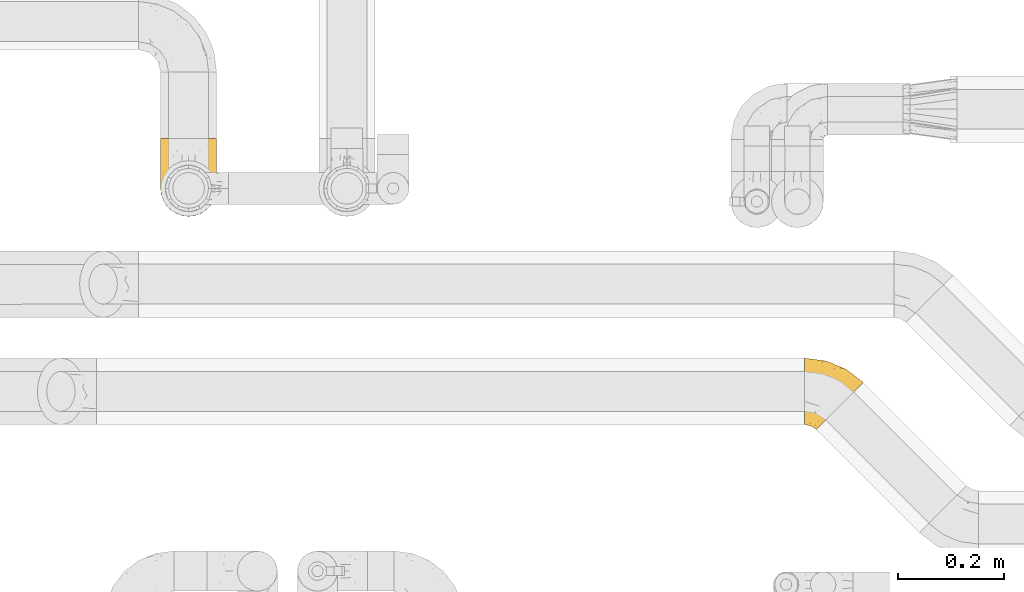
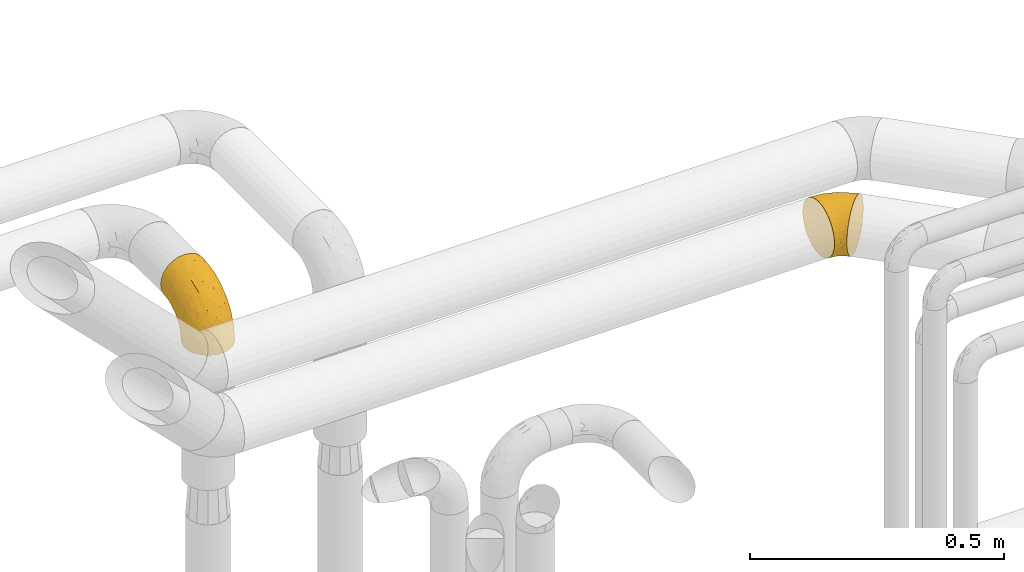
# One storey, part 407 of 827: 2 coverings.
"""IFC2X3 building model written with IfcOpenShell, lengths in millimetres."""

from ifc_helpers import new_model, entity, si_unit, converted_unit, derived_unit, direction, frame, origin, place, context, subcontext, project, spatial, faceted_brep, element, save


model = new_model("IFC2X3")

# Units and contexts
model_context = context("Model", 3, precision=0.01, world=origin(), true_north=direction((6.12303176911189e-17, 1.0)))
body_context = subcontext(model_context, "Body", "Model", "MODEL_VIEW")
ifc_project = project(units=[si_unit("LENGTHUNIT", "METRE", prefix="MILLI"), si_unit("AREAUNIT", "SQUARE_METRE"), si_unit("VOLUMEUNIT", "CUBIC_METRE"), converted_unit("PLANEANGLEUNIT", "DEGREE", entity("IfcRatioMeasure", 0.0174532925199433), si_unit("PLANEANGLEUNIT", "RADIAN"), dimensions=[0, 0, 0, 0, 0, 0, 0]), si_unit("MASSUNIT", "GRAM", prefix="KILO"), derived_unit("MASSDENSITYUNIT", [(si_unit("MASSUNIT", "GRAM", prefix="KILO"), 1), (si_unit("LENGTHUNIT", "METRE"), -3)]), derived_unit("MOMENTOFINERTIAUNIT", [(si_unit("LENGTHUNIT", "METRE"), 4)]), si_unit("TIMEUNIT", "SECOND"), si_unit("FREQUENCYUNIT", "HERTZ"), si_unit("THERMODYNAMICTEMPERATUREUNIT", "DEGREE_CELSIUS"), derived_unit("THERMALTRANSMITTANCEUNIT", [(si_unit("MASSUNIT", "GRAM", prefix="KILO"), 1), (si_unit("THERMODYNAMICTEMPERATUREUNIT", "KELVIN"), -1), (si_unit("TIMEUNIT", "SECOND"), -3)]), derived_unit("VOLUMETRICFLOWRATEUNIT", [(si_unit("LENGTHUNIT", "METRE"), 3), (si_unit("TIMEUNIT", "SECOND"), -1)]), derived_unit("MASSFLOWRATEUNIT", [(si_unit("MASSUNIT", "GRAM", prefix="KILO"), 1), (si_unit("TIMEUNIT", "SECOND"), -1)]), derived_unit("ROTATIONALFREQUENCYUNIT", [(si_unit("TIMEUNIT", "SECOND"), -1)]), si_unit("ELECTRICCURRENTUNIT", "AMPERE"), si_unit("ELECTRICVOLTAGEUNIT", "VOLT"), si_unit("POWERUNIT", "WATT"), si_unit("FORCEUNIT", "NEWTON", prefix="KILO"), si_unit("ILLUMINANCEUNIT", "LUX"), si_unit("LUMINOUSFLUXUNIT", "LUMEN"), si_unit("LUMINOUSINTENSITYUNIT", "CANDELA"), derived_unit("USERDEFINED", [(si_unit("MASSUNIT", "GRAM", prefix="KILO"), -1), (si_unit("LENGTHUNIT", "METRE"), -2), (si_unit("TIMEUNIT", "SECOND"), 3), (si_unit("LUMINOUSFLUXUNIT", "LUMEN"), 1)]), derived_unit("LINEARVELOCITYUNIT", [(si_unit("LENGTHUNIT", "METRE"), 1), (si_unit("TIMEUNIT", "SECOND"), -1)]), si_unit("PRESSUREUNIT", "PASCAL"), derived_unit("USERDEFINED", [(si_unit("LENGTHUNIT", "METRE"), -2), (si_unit("MASSUNIT", "GRAM", prefix="KILO"), 1), (si_unit("TIMEUNIT", "SECOND"), -2)]), derived_unit("LINEARFORCEUNIT", [(si_unit("MASSUNIT", "GRAM", prefix="KILO"), 1), (si_unit("LENGTHUNIT", "METRE"), 1), (si_unit("TIMEUNIT", "SECOND"), -2), (si_unit("LENGTHUNIT", "METRE"), -1)]), derived_unit("PLANARFORCEUNIT", [(si_unit("MASSUNIT", "GRAM", prefix="KILO"), 1), (si_unit("LENGTHUNIT", "METRE"), 1), (si_unit("TIMEUNIT", "SECOND"), -2), (si_unit("LENGTHUNIT", "METRE"), -2)])], contexts=[model_context])

# Site, building, storey
site_placement = place(None, origin())
site = spatial("IfcSite", under=ifc_project, at=site_placement, CompositionType="ELEMENT")
building_placement = place(site_placement, origin())
building = spatial("IfcBuilding", under=site, at=building_placement, CompositionType="ELEMENT")
storey_placement = place(building_placement, frame((0.0, 0.0, 28200.0)))
storey = spatial("IfcBuildingStorey", under=building, at=storey_placement, Name="08", CompositionType="ELEMENT", Elevation=28200.0)

# Coverings
covering_1_placement = place(storey_placement, frame((47672.87, 18532.7, 2935.35)))
element("IfcCovering", 1, at=covering_1_placement, inside=storey, Name=":ADSK_", ObjectType=":ADSK_", PredefinedType="INSULATION", context=body_context, shape_type="Brep", body=[
    faceted_brep([(1.6, 12.53, 50.61), (1.6, 10.95, 64.65), (1.6, 12.53, 78.67), (1.6, 17.2, 92.0), (1.6, 24.71, 103.95), (1.6, 34.69, 113.94), (1.6, 46.64, 121.45), (1.6, 59.97, 126.11), (1.6, 74.0, 127.7), (1.6, 88.03, 126.11), (1.6, 101.36, 121.45), (1.6, 113.31, 113.94), (1.6, 123.3, 103.96), (1.6, 130.81, 92.0), (1.6, 135.47, 78.68), (1.6, 137.05, 64.65), (1.6, 135.47, 50.62), (1.6, 130.81, 37.29), (1.6, 123.3, 25.34), (1.6, 113.32, 15.35), (1.6, 101.36, 7.84), (1.6, 88.04, 3.18), (1.6, 74.0, 1.6), (1.6, 59.97, 3.18), (1.6, 46.65, 7.84), (1.6, 34.69, 15.35), (1.6, 24.71, 25.33), (1.6, 17.2, 37.29), (24.19, 1.6, 64.65), (25.71, 3.11, 48.33), (30.16, 7.57, 33.12), (37.25, 14.65, 20.06), (46.48, 23.89, 10.04), (57.23, 34.64, 3.74), (68.77, 46.18, 1.6), (80.31, 57.72, 3.74), (91.06, 68.47, 10.04), (100.3, 77.7, 20.06), (107.38, 84.79, 33.12), (111.83, 89.24, 48.33), (113.35, 90.76, 64.65), (111.83, 89.24, 80.96), (107.38, 84.79, 96.17), (100.3, 77.7, 109.23), (91.06, 68.47, 119.25), (80.31, 57.72, 125.55), (68.77, 46.18, 127.7), (57.23, 34.64, 125.55), (46.48, 23.89, 119.25), (37.25, 14.65, 109.23), (30.16, 7.57, 96.17), (25.71, 3.11, 80.96), (32.7, 116.2, 108.1), (80.62, 115.88, 64.65), (93.11, 105.47, 80.19), (82.84, 100.01, 102.05), (42.5, 131.67, 64.65), (71.97, 118.02, 81.27), (45.26, 84.43, 124.73), (69.34, 78.79, 122.26), (36.12, 129.91, 84.6), (59.89, 101.26, 113.02), (49.1, 61.28, 127.7), (58.8, 53.83, 127.7), (28.22, 125.53, 97.32), (57.99, 117.49, 96.3), (28.36, 106.16, 117.12), (88.29, 104.46, 90.52), (14.06, 72.36, 127.7), (26.18, 70.77, 127.7), (37.64, 66.02, 127.7), (49.88, 94.73, 119.88), (12.25, 43.42, 120.26), (14.66, 57.99, 125.9), (44.99, 42.69, 125.09), (33.47, 31.37, 117.94), (14.23, 31.23, 112.32), (24.69, 45.08, 122.53), (18.1, 20.17, 102.2), (28.08, 17.46, 105.16), (23.85, 27.0, 111.58), (8.9, 21.15, 99.98), (19.06, 6.66, 74.42), (13.18, 13.45, 87.77), (10.63, 10.72, 75.98), (27.52, 58.08, 126.59), (35.9, 50.06, 125.61), (22.27, 10.21, 90.37), (13.82, 8.52, 64.65), (13.18, 13.45, 41.51), (14.23, 31.24, 16.97), (17.42, 8.21, 52.07), (33.46, 31.38, 11.35), (44.99, 42.69, 4.2), (21.94, 12.47, 35.35), (18.11, 20.17, 27.09), (58.8, 53.83, 1.6), (27.53, 58.09, 2.7), (26.18, 70.77, 1.6), (37.64, 66.02, 1.6), (12.25, 43.43, 9.03), (24.69, 45.08, 6.76), (37.86, 53.03, 2.86), (35.77, 41.85, 6.13), (28.08, 17.46, 24.13), (23.85, 27.0, 17.7), (14.66, 57.99, 3.39), (8.9, 21.16, 29.31), (14.06, 72.36, 1.6), (49.1, 61.28, 1.6), (45.26, 84.43, 4.56), (69.34, 78.79, 7.03), (32.7, 116.21, 21.19), (59.88, 101.26, 16.27), (28.36, 106.17, 12.17), (28.23, 125.53, 31.97), (57.99, 117.5, 33.0), (82.84, 100.01, 27.24), (93.11, 105.47, 49.11), (88.29, 104.46, 38.77), (36.12, 129.91, 44.69), (71.97, 118.03, 48.02), (49.88, 94.73, 9.41)], [[[0, 1, 2, 3, 4, 5, 6, 7, 8, 9, 10, 11, 12, 13, 14, 15, 16, 17, 18, 19, 20, 21, 22, 23, 24, 25, 26, 27]], [[28, 29, 30, 31, 32, 33, 34, 35, 36, 37, 38, 39, 40, 41, 42, 43, 44, 45, 46, 47, 48, 49, 50, 51]], [[52, 12, 11]], [[40, 53, 54]], [[42, 55, 43]], [[53, 56, 57]], [[10, 9, 58]], [[45, 59, 58]], [[56, 14, 60]], [[61, 44, 43]], [[45, 62, 63, 46]], [[62, 45, 58]], [[59, 45, 44]], [[64, 52, 65]], [[55, 61, 43]], [[61, 65, 52]], [[60, 57, 56]], [[60, 65, 57]], [[52, 11, 66]], [[64, 13, 12]], [[64, 60, 13]], [[14, 56, 15]], [[61, 55, 65]], [[67, 55, 42]], [[54, 67, 41]], [[61, 52, 66]], [[66, 11, 10]], [[9, 8, 68, 69]], [[58, 69, 70, 62]], [[58, 9, 69]], [[60, 64, 65]], [[52, 64, 12]], [[58, 59, 71]], [[54, 57, 67]], [[58, 66, 10]], [[60, 14, 13]], [[41, 67, 42]], [[65, 55, 67]], [[65, 67, 57]], [[40, 54, 41]], [[53, 57, 54]], [[44, 61, 59]], [[58, 71, 66]], [[59, 61, 71]], [[61, 66, 71]], [[72, 73, 6]], [[62, 74, 63]], [[48, 75, 49]], [[63, 74, 47]], [[75, 48, 74]], [[72, 76, 77]], [[78, 79, 80]], [[81, 4, 3]], [[82, 28, 51]], [[83, 84, 82]], [[73, 77, 85]], [[86, 62, 70]], [[83, 87, 78]], [[50, 87, 51]], [[86, 75, 74]], [[68, 73, 69]], [[6, 5, 72]], [[73, 7, 6]], [[74, 48, 47]], [[73, 68, 7]], [[80, 77, 76]], [[69, 85, 70]], [[81, 76, 4]], [[88, 84, 1]], [[84, 83, 2]], [[2, 83, 3]], [[4, 76, 5]], [[50, 49, 79]], [[83, 78, 81]], [[80, 76, 78]], [[73, 72, 77]], [[76, 72, 5]], [[85, 86, 70]], [[68, 8, 7]], [[73, 85, 69]], [[86, 85, 77]], [[75, 86, 77]], [[86, 74, 62]], [[47, 46, 63]], [[83, 81, 3]], [[76, 81, 78]], [[75, 79, 49]], [[87, 79, 78]], [[79, 75, 80]], [[77, 80, 75]], [[1, 84, 2]], [[82, 84, 88]], [[28, 82, 88]], [[82, 51, 87]], [[87, 50, 79]], [[82, 87, 83]], [[0, 27, 89]], [[26, 25, 90]], [[88, 91, 28]], [[32, 92, 93]], [[94, 89, 95]], [[94, 29, 91]], [[93, 96, 33]], [[97, 98, 99]], [[25, 24, 100]], [[101, 102, 103]], [[104, 95, 105]], [[93, 33, 32]], [[100, 90, 25]], [[102, 97, 99]], [[91, 0, 89]], [[97, 106, 98]], [[27, 107, 89]], [[93, 92, 103]], [[90, 95, 107]], [[31, 92, 32]], [[31, 30, 104]], [[107, 27, 26]], [[24, 23, 106]], [[101, 97, 102]], [[89, 94, 91]], [[31, 104, 92]], [[98, 106, 108]], [[106, 23, 108]], [[100, 106, 101]], [[101, 92, 105]], [[106, 100, 24]], [[0, 88, 1]], [[90, 100, 101]], [[23, 22, 108]], [[93, 102, 109]], [[106, 97, 101]], [[109, 102, 99]], [[102, 93, 103]], [[96, 93, 109]], [[96, 34, 33]], [[101, 103, 92]], [[90, 107, 26]], [[89, 107, 95]], [[94, 104, 30]], [[95, 90, 105]], [[101, 105, 90]], [[92, 104, 105]], [[104, 94, 95]], [[29, 94, 30]], [[28, 91, 29]], [[0, 91, 88]], [[35, 110, 111]], [[112, 113, 114]], [[35, 34, 96, 109]], [[112, 114, 19]], [[112, 115, 116]], [[117, 113, 116]], [[39, 118, 40]], [[116, 119, 117]], [[120, 121, 116]], [[113, 117, 37]], [[36, 113, 37]], [[38, 117, 119]], [[119, 116, 121]], [[21, 20, 110]], [[110, 109, 99, 98]], [[122, 111, 110]], [[21, 98, 108, 22]], [[37, 117, 38]], [[112, 19, 18]], [[39, 119, 118]], [[116, 113, 112]], [[110, 35, 109]], [[119, 39, 38]], [[114, 20, 19]], [[121, 120, 56]], [[115, 18, 17]], [[16, 15, 56]], [[16, 56, 120]], [[110, 20, 114]], [[115, 120, 116]], [[121, 56, 53]], [[16, 120, 17]], [[115, 112, 18]], [[21, 110, 98]], [[120, 115, 17]], [[35, 111, 36]], [[119, 121, 118]], [[121, 53, 118]], [[40, 118, 53]], [[122, 110, 114]], [[113, 36, 111]], [[114, 113, 122]], [[113, 111, 122]]]),
])
covering_2_placement = place(storey_placement, frame((46453.17, 18936.58, 2903.4)))
element("IfcCovering", 2, at=covering_2_placement, inside=storey, Name=":ADSK_", ObjectType=":ADSK_", PredefinedType="INSULATION", context=body_context, shape_type="Brep", body=[
    faceted_brep([(66.44, 2.92, 1.6), (54.65, 1.6, 1.6), (42.84, 2.93, 1.6), (31.62, 6.85, 1.6), (21.56, 13.18, 1.6), (13.16, 21.58, 1.6), (6.84, 31.64, 1.6), (2.92, 42.85, 1.6), (1.6, 54.65, 1.6), (2.93, 66.46, 1.6), (6.85, 77.67, 1.6), (13.18, 87.73, 1.6), (21.58, 96.13, 1.6), (31.64, 102.45, 1.6), (42.85, 106.37, 1.6), (54.65, 107.7, 1.6), (66.46, 106.36, 1.6), (77.67, 102.44, 1.6), (87.73, 96.11, 1.6), (96.13, 87.71, 1.6), (102.45, 77.65, 1.6), (106.37, 66.44, 1.6), (107.7, 54.65, 1.6), (106.36, 42.84, 1.6), (102.44, 31.62, 1.6), (96.11, 21.56, 1.6), (87.71, 13.16, 1.6), (77.65, 6.84, 1.6), (40.91, 149.65, 45.35), (28.12, 149.65, 50.65), (17.13, 149.65, 59.08), (8.7, 149.65, 70.07), (3.4, 149.65, 82.86), (1.6, 149.65, 96.6), (3.4, 149.65, 110.33), (8.7, 149.65, 123.12), (17.13, 149.65, 134.11), (28.12, 149.65, 142.54), (40.91, 149.65, 147.84), (54.65, 149.65, 149.65), (68.38, 149.65, 147.84), (81.17, 149.65, 142.54), (92.16, 149.65, 134.11), (100.59, 149.65, 123.12), (105.89, 149.65, 110.33), (107.7, 149.65, 96.6), (105.89, 149.65, 82.86), (100.59, 149.65, 70.07), (92.16, 149.65, 59.08), (81.17, 149.65, 50.65), (68.38, 149.65, 45.35), (54.65, 149.65, 43.55), (85.53, 123.27, 137.19), (73.42, 114.15, 141.79), (83.77, 92.97, 128.89), (64.22, 124.11, 146.54), (54.65, 111.33, 144.6), (96.72, 42.13, 69.77), (93.36, 56.83, 94.41), (84.47, 40.31, 87.22), (71.37, 61.55, 117.2), (54.65, 75.62, 129.81), (54.65, 44.96, 106.28), (103.47, 91.12, 101.45), (100.91, 109.83, 115.81), (99.1, 88.02, 109.14), (105.43, 119.19, 107.65), (106.79, 99.11, 93.36), (89.81, 27.97, 59.44), (79.59, 21.92, 63.23), (81.29, 12.94, 35.59), (74.01, 88.29, 132.3), (64.14, 95.35, 138.41), (94.75, 113.84, 126.28), (54.65, 6.64, 39.91), (70.74, 8.58, 37.44), (68.3, 33.39, 90.35), (66.05, 17.23, 65.0), (100.73, 61.99, 85.4), (106.78, 47.9, 26.66), (103.6, 37.72, 29.88), (107.7, 93.81, 78.45), (107.7, 107.05, 85.2), (107.7, 120.29, 91.95), (106.07, 73.26, 77.98), (90.59, 18.58, 29.55), (97.43, 29.72, 41.42), (84.51, 64.31, 111.13), (93.3, 82.84, 114.67), (107.7, 72.79, 57.43), (107.7, 83.3, 67.94), (107.7, 56.71, 14.64), (107.7, 59.29, 30.95), (106.79, 57.88, 52.13), (107.7, 66.04, 44.19), (103.47, 49.8, 60.12), (54.65, 21.43, 75.62), (107.7, 134.97, 94.27), (76.99, 108.79, 24.59), (84.28, 110.84, 34.69), (91.11, 101.53, 31.15), (106.26, 111.84, 75.18), (102.6, 119.98, 67.55), (106.08, 123.54, 79.36), (106.56, 134.54, 84.32), (105.36, 80.57, 40.81), (106.74, 69.55, 29.93), (101.59, 134.56, 70.24), (54.65, 128.67, 37.93), (54.65, 136.98, 40.15), (67.71, 133.56, 42.1), (91.36, 131.66, 55.38), (94.33, 117.75, 52.17), (87.1, 118.23, 44.32), (65.84, 110.55, 19.85), (54.65, 111.09, 14.26), (54.65, 113.32, 22.57), (68.92, 120.2, 34.17), (100.82, 105.95, 54.85), (79.83, 127.69, 44.63), (77.13, 139.88, 47.52), (105.9, 92.14, 59.1), (101.53, 93.82, 44.11), (106.72, 82.28, 53.21), (97.75, 130.86, 62.86), (103.08, 78.78, 20.58), (106.39, 67.58, 15.79), (98.1, 90.58, 27.67), (95.02, 90.23, 13.49), (86.9, 99.39, 18.04), (74.42, 105.17, 12.44), (54.65, 120.99, 30.25), (105.28, 104.59, 66.71), (92.87, 108.24, 42.52), (17.93, 131.66, 55.38), (6.22, 78.8, 20.57), (41.58, 133.57, 42.11), (1.6, 72.79, 57.43), (2.57, 82.27, 53.22), (3.94, 80.59, 40.81), (43.46, 110.55, 19.85), (32.32, 108.79, 24.58), (40.38, 120.2, 34.16), (16.44, 108.25, 42.5), (8.47, 106.06, 54.93), (15.01, 117.78, 52.13), (11.21, 90.6, 27.66), (7.78, 93.87, 44.12), (1.6, 93.81, 78.45), (1.6, 107.05, 85.2), (3.04, 111.89, 75.17), (1.6, 134.97, 94.27), (2.73, 134.54, 84.32), (1.6, 59.29, 30.95), (1.6, 66.04, 44.19), (2.55, 69.56, 29.98), (3.98, 104.56, 66.78), (6.69, 119.98, 67.55), (7.7, 134.56, 70.24), (3.21, 123.54, 79.36), (14.28, 90.25, 13.48), (22.42, 99.4, 18.03), (25.02, 110.83, 34.66), (18.18, 101.52, 31.14), (34.89, 105.18, 12.43), (1.6, 56.71, 14.64), (32.17, 139.89, 47.52), (22.23, 118.22, 44.28), (2.91, 67.6, 15.8), (11.54, 130.86, 62.86), (1.6, 83.3, 67.94), (29.46, 127.71, 44.64), (3.38, 92.12, 59.12), (1.6, 120.29, 91.95), (25.52, 92.97, 128.89), (23.76, 123.27, 137.19), (14.54, 113.84, 126.28), (8.38, 109.83, 115.81), (45.07, 124.03, 146.53), (35.87, 114.15, 141.79), (45.14, 98.04, 139.45), (2.5, 99.11, 93.36), (2.51, 47.9, 26.67), (5.68, 37.74, 29.87), (5.82, 49.8, 60.12), (15.93, 56.83, 94.41), (12.54, 42.16, 69.76), (24.81, 40.3, 87.19), (2.5, 57.88, 52.13), (3.22, 73.26, 77.98), (3.86, 119.19, 107.65), (35.85, 86.61, 131.74), (19.47, 27.99, 59.44), (18.68, 18.59, 29.54), (29.68, 21.92, 63.2), (27.95, 11.28, 27.9), (40.99, 33.39, 90.35), (37.92, 61.55, 117.2), (11.85, 29.73, 41.39), (10.19, 88.01, 109.14), (8.55, 62.08, 85.46), (38.53, 8.58, 37.43), (15.99, 82.84, 114.67), (24.79, 64.3, 111.12), (5.82, 91.12, 101.45), (40.56, 18.05, 65.16)], [[[0, 1, 2, 3, 4, 5, 6, 7, 8, 9, 10, 11, 12, 13, 14, 15, 16, 17, 18, 19, 20, 21, 22, 23, 24, 25, 26, 27]], [[28, 29, 30, 31, 32, 33, 34, 35, 36, 37, 38, 39, 40, 41, 42, 43, 44, 45, 46, 47, 48, 49, 50, 51]], [[52, 53, 54]], [[55, 39, 56]], [[57, 58, 59]], [[60, 61, 62]], [[63, 64, 65]], [[66, 63, 67]], [[68, 69, 70]], [[53, 71, 54]], [[41, 40, 53]], [[53, 72, 71]], [[73, 42, 52]], [[42, 41, 52]], [[74, 0, 75]], [[69, 76, 77]], [[43, 73, 64]], [[45, 44, 66]], [[57, 78, 58]], [[23, 79, 80]], [[67, 81, 82, 83]], [[67, 84, 81]], [[24, 23, 80]], [[25, 85, 26]], [[86, 85, 25]], [[42, 73, 43]], [[0, 27, 75]], [[25, 24, 86]], [[70, 26, 85]], [[0, 74, 1]], [[68, 85, 86]], [[66, 64, 63]], [[60, 59, 87]], [[54, 87, 88]], [[76, 60, 62]], [[84, 89, 90, 81]], [[79, 22, 91, 92]], [[77, 74, 75]], [[93, 92, 94, 89]], [[80, 86, 24]], [[40, 55, 53]], [[76, 59, 60]], [[93, 84, 95]], [[76, 62, 96]], [[55, 72, 53]], [[70, 27, 26]], [[75, 70, 69]], [[78, 84, 63]], [[93, 79, 92]], [[95, 86, 80]], [[77, 76, 96]], [[59, 69, 68]], [[57, 68, 86]], [[68, 57, 59]], [[59, 58, 87]], [[76, 69, 59]], [[88, 87, 58]], [[87, 54, 71]], [[86, 95, 57]], [[78, 57, 95]], [[84, 78, 95]], [[78, 63, 65]], [[58, 78, 65]], [[54, 88, 73]], [[84, 93, 89]], [[79, 95, 80]], [[79, 93, 95]], [[22, 79, 23]], [[66, 83, 97, 45]], [[84, 67, 63]], [[83, 66, 67]], [[64, 44, 43]], [[64, 66, 44]], [[65, 73, 88]], [[53, 52, 41]], [[73, 52, 54]], [[73, 65, 64]], [[65, 88, 58]], [[39, 55, 40]], [[72, 55, 56]], [[56, 61, 72]], [[60, 72, 61]], [[72, 60, 71]], [[87, 71, 60]], [[27, 70, 75]], [[68, 70, 85]], [[74, 77, 96]], [[69, 77, 75]], [[98, 99, 100]], [[46, 45, 97]], [[101, 102, 103]], [[103, 104, 83]], [[105, 94, 106]], [[107, 103, 102]], [[108, 109, 51, 110]], [[111, 112, 113]], [[114, 115, 116]], [[47, 104, 107]], [[110, 117, 108]], [[49, 48, 111]], [[102, 118, 112]], [[119, 120, 111]], [[50, 49, 120]], [[121, 122, 118]], [[105, 123, 89]], [[124, 48, 107]], [[20, 19, 125]], [[121, 81, 90]], [[117, 119, 99]], [[21, 20, 126]], [[22, 21, 91]], [[105, 125, 127]], [[110, 51, 50]], [[19, 128, 125]], [[16, 15, 115]], [[129, 98, 100]], [[126, 91, 21]], [[128, 129, 127]], [[122, 123, 105]], [[114, 117, 98]], [[17, 16, 130]], [[18, 128, 19]], [[129, 18, 17]], [[125, 106, 126]], [[115, 114, 16]], [[130, 129, 17]], [[114, 98, 130]], [[117, 116, 131, 108]], [[99, 119, 113]], [[122, 121, 123]], [[92, 126, 106]], [[105, 127, 122]], [[132, 121, 118]], [[114, 130, 16]], [[129, 130, 98]], [[50, 120, 110]], [[129, 128, 18]], [[125, 128, 127]], [[125, 126, 20]], [[91, 126, 92]], [[105, 89, 94]], [[105, 106, 125]], [[94, 92, 106]], [[100, 122, 127]], [[118, 122, 133]], [[112, 118, 133]], [[132, 118, 102]], [[132, 102, 101]], [[81, 121, 132]], [[82, 103, 83]], [[132, 101, 81]], [[104, 47, 46]], [[124, 107, 102]], [[48, 47, 107]], [[113, 112, 133]], [[112, 111, 124]], [[99, 113, 133]], [[111, 113, 119]], [[99, 133, 100]], [[117, 99, 98]], [[122, 100, 133]], [[127, 129, 100]], [[103, 82, 101]], [[81, 101, 82]], [[112, 124, 102]], [[48, 124, 111]], [[104, 103, 107]], [[46, 97, 104]], [[111, 120, 49]], [[83, 104, 97]], [[110, 120, 119]], [[117, 110, 119]], [[116, 117, 114]], [[89, 123, 90]], [[90, 123, 121]], [[30, 29, 134]], [[11, 10, 135]], [[51, 109, 108, 136]], [[137, 138, 139]], [[140, 141, 142]], [[143, 144, 145]], [[146, 139, 147]], [[148, 149, 150]], [[151, 32, 152]], [[153, 154, 155]], [[156, 150, 157]], [[158, 157, 159]], [[108, 142, 136]], [[31, 158, 152]], [[160, 161, 12]], [[162, 163, 143]], [[140, 142, 116]], [[142, 141, 162]], [[14, 164, 140]], [[14, 140, 115]], [[9, 8, 165]], [[160, 12, 11]], [[141, 164, 161]], [[13, 12, 161]], [[14, 115, 15]], [[28, 166, 29]], [[135, 139, 146]], [[141, 163, 162]], [[135, 146, 160]], [[143, 167, 162]], [[29, 166, 134]], [[116, 142, 108, 131]], [[165, 153, 168]], [[10, 9, 168]], [[168, 135, 10]], [[138, 147, 139]], [[158, 169, 157]], [[14, 13, 164]], [[116, 115, 140]], [[145, 167, 143]], [[135, 160, 11]], [[168, 153, 155]], [[138, 137, 170]], [[157, 144, 156]], [[147, 144, 143]], [[161, 164, 13]], [[140, 164, 141]], [[142, 171, 136]], [[136, 171, 166]], [[161, 160, 146]], [[165, 168, 9]], [[155, 139, 135]], [[139, 154, 137]], [[168, 155, 135]], [[139, 155, 154]], [[144, 147, 172]], [[163, 147, 143]], [[156, 144, 172]], [[157, 169, 145]], [[172, 148, 156]], [[173, 159, 149]], [[159, 157, 150]], [[152, 159, 173]], [[159, 152, 158]], [[31, 30, 158]], [[169, 30, 134]], [[157, 145, 144]], [[167, 134, 171]], [[134, 167, 145]], [[171, 142, 162]], [[162, 167, 171]], [[163, 141, 161]], [[161, 146, 163]], [[147, 163, 146]], [[148, 150, 156]], [[149, 159, 150]], [[30, 169, 158]], [[145, 169, 134]], [[151, 33, 32]], [[31, 152, 32]], [[152, 173, 151]], [[28, 51, 136]], [[134, 166, 171]], [[28, 136, 166]], [[138, 170, 172]], [[147, 138, 172]], [[148, 172, 170]], [[174, 175, 176]], [[35, 34, 177]], [[178, 179, 180]], [[181, 173, 149, 148]], [[182, 183, 184]], [[185, 186, 187]], [[188, 189, 137]], [[190, 33, 151, 173]], [[191, 179, 174]], [[34, 190, 177]], [[39, 38, 178]], [[192, 193, 194]], [[4, 3, 195]], [[175, 179, 37]], [[38, 37, 179]], [[35, 176, 36]], [[196, 62, 197]], [[181, 190, 173]], [[37, 36, 175]], [[183, 6, 198]], [[189, 148, 170, 137]], [[185, 199, 200]], [[3, 2, 201]], [[202, 185, 203]], [[8, 7, 182]], [[200, 184, 186]], [[183, 7, 6]], [[181, 189, 204]], [[200, 189, 184]], [[5, 198, 6]], [[187, 203, 185]], [[195, 3, 201]], [[205, 196, 194]], [[62, 61, 197]], [[186, 198, 192]], [[180, 179, 191]], [[2, 1, 74]], [[198, 193, 192]], [[193, 5, 4]], [[194, 193, 195]], [[2, 74, 201]], [[5, 193, 198]], [[205, 74, 96]], [[188, 137, 154, 153]], [[62, 196, 96]], [[56, 178, 180]], [[198, 184, 183]], [[184, 188, 182]], [[203, 197, 191]], [[205, 194, 201]], [[187, 192, 194]], [[192, 187, 186]], [[194, 196, 187]], [[197, 187, 196]], [[197, 203, 187]], [[202, 174, 176]], [[200, 186, 185]], [[184, 198, 186]], [[199, 185, 202]], [[189, 200, 204]], [[174, 202, 203]], [[176, 177, 199]], [[189, 181, 148]], [[190, 181, 204]], [[190, 204, 177]], [[190, 34, 33]], [[188, 153, 182]], [[189, 188, 184]], [[182, 153, 165, 8]], [[183, 182, 7]], [[199, 177, 204]], [[35, 177, 176]], [[176, 175, 36]], [[179, 175, 174]], [[200, 199, 204]], [[176, 199, 202]], [[203, 191, 174]], [[180, 197, 61]], [[197, 180, 191]], [[61, 56, 180]], [[39, 178, 56]], [[38, 179, 178]], [[194, 195, 201]], [[4, 195, 193]], [[74, 205, 201]], [[96, 196, 205]]]),
])

save(model, "model.ifc")
